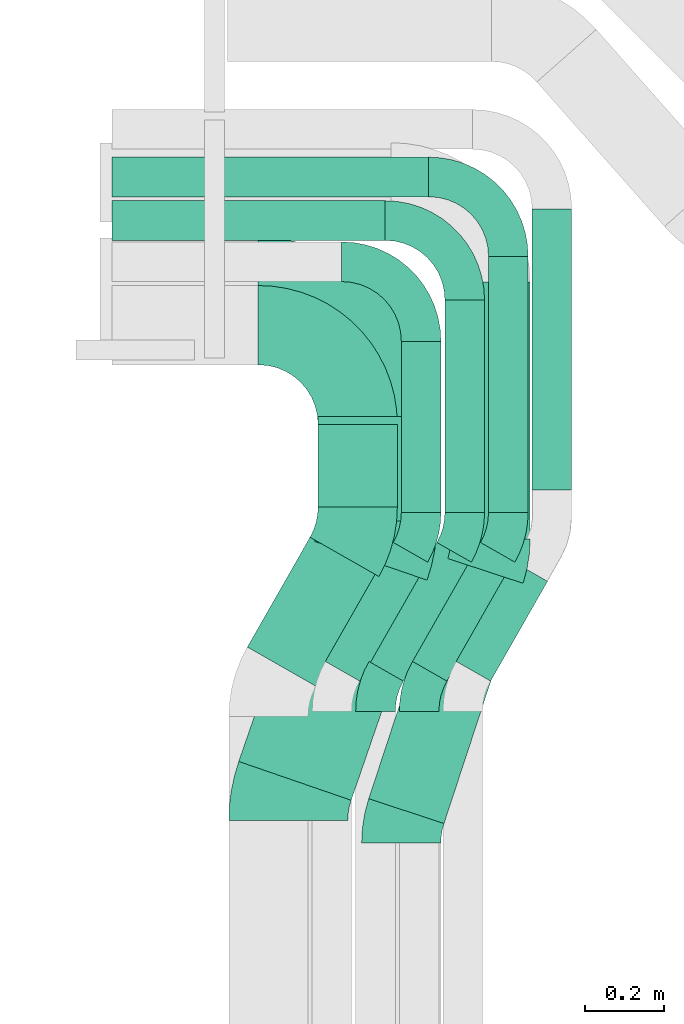
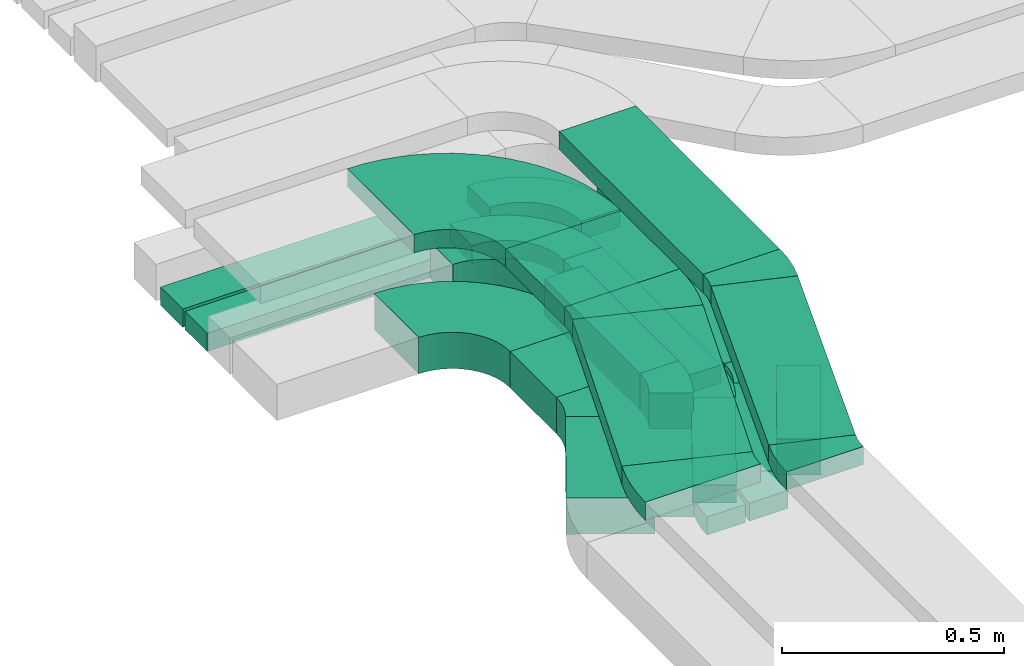
# One storey, part 6 of 31: 16 flow segments, 15 flow fittings.
"""IFC2X3 building model written with IfcOpenShell, lengths in millimetres."""

from ifc_helpers import new_model, entity, si_unit, converted_unit, derived_unit, direction, frame, frame_2d, origin, origin_2d_with_axis, place, context, subcontext, project, spatial, polyline, circle_curve, parameter, trimmed, segment, composite_curve, rectangle, outline, extrude, source, transform, mapped, material, type_object, type_shapes, element, save


model = new_model("IFC2X3")

# Units and contexts
model_context = context("Model", 3, precision=0.01, world=origin(), true_north=direction((6.12303176911189e-17, 1.0)))
body_context = subcontext(model_context, "Body", "Model", "MODEL_VIEW")
ifc_project = project(units=[si_unit("LENGTHUNIT", "METRE", prefix="MILLI"), si_unit("AREAUNIT", "SQUARE_METRE"), si_unit("VOLUMEUNIT", "CUBIC_METRE"), converted_unit("PLANEANGLEUNIT", "DEGREE", entity("IfcRatioMeasure", 0.0174532925199433), si_unit("PLANEANGLEUNIT", "RADIAN"), dimensions=[0, 0, 0, 0, 0, 0, 0]), si_unit("MASSUNIT", "GRAM", prefix="KILO"), derived_unit("MASSDENSITYUNIT", [(si_unit("MASSUNIT", "GRAM", prefix="KILO"), 1), (si_unit("LENGTHUNIT", "METRE"), -3)]), derived_unit("MOMENTOFINERTIAUNIT", [(si_unit("LENGTHUNIT", "METRE"), 4)]), si_unit("TIMEUNIT", "SECOND"), si_unit("FREQUENCYUNIT", "HERTZ"), si_unit("THERMODYNAMICTEMPERATUREUNIT", "DEGREE_CELSIUS"), derived_unit("THERMALTRANSMITTANCEUNIT", [(si_unit("MASSUNIT", "GRAM", prefix="KILO"), 1), (si_unit("THERMODYNAMICTEMPERATUREUNIT", "KELVIN"), -1), (si_unit("TIMEUNIT", "SECOND"), -3)]), derived_unit("VOLUMETRICFLOWRATEUNIT", [(si_unit("LENGTHUNIT", "METRE"), 3), (si_unit("TIMEUNIT", "SECOND"), -1)]), derived_unit("MASSFLOWRATEUNIT", [(si_unit("MASSUNIT", "GRAM", prefix="KILO"), 1), (si_unit("TIMEUNIT", "SECOND"), -1)]), derived_unit("ROTATIONALFREQUENCYUNIT", [(si_unit("TIMEUNIT", "SECOND"), -1)]), si_unit("ELECTRICCURRENTUNIT", "AMPERE"), si_unit("ELECTRICVOLTAGEUNIT", "VOLT"), si_unit("POWERUNIT", "WATT"), si_unit("FORCEUNIT", "NEWTON", prefix="KILO"), si_unit("ILLUMINANCEUNIT", "LUX"), si_unit("LUMINOUSFLUXUNIT", "LUMEN"), si_unit("LUMINOUSINTENSITYUNIT", "CANDELA"), derived_unit("USERDEFINED", [(si_unit("MASSUNIT", "GRAM", prefix="KILO"), -1), (si_unit("LENGTHUNIT", "METRE"), -2), (si_unit("TIMEUNIT", "SECOND"), 3), (si_unit("LUMINOUSFLUXUNIT", "LUMEN"), 1)]), derived_unit("LINEARVELOCITYUNIT", [(si_unit("LENGTHUNIT", "METRE"), 1), (si_unit("TIMEUNIT", "SECOND"), -1)]), si_unit("PRESSUREUNIT", "PASCAL"), derived_unit("USERDEFINED", [(si_unit("LENGTHUNIT", "METRE"), -2), (si_unit("MASSUNIT", "GRAM", prefix="KILO"), 1), (si_unit("TIMEUNIT", "SECOND"), -2)]), derived_unit("LINEARFORCEUNIT", [(si_unit("MASSUNIT", "GRAM", prefix="KILO"), 1), (si_unit("LENGTHUNIT", "METRE"), 1), (si_unit("TIMEUNIT", "SECOND"), -2), (si_unit("LENGTHUNIT", "METRE"), -1)]), derived_unit("PLANARFORCEUNIT", [(si_unit("MASSUNIT", "GRAM", prefix="KILO"), 1), (si_unit("LENGTHUNIT", "METRE"), 1), (si_unit("TIMEUNIT", "SECOND"), -2), (si_unit("LENGTHUNIT", "METRE"), -2)])], contexts=[model_context])

# Site, building, storey
site_placement = place(None, frame((0.0, -0.00077364408347762, 0.0)))
site = spatial("IfcSite", under=ifc_project, at=site_placement, CompositionType="ELEMENT")
building_placement = place(site_placement, origin())
building = spatial("IfcBuilding", under=site, at=building_placement, CompositionType="ELEMENT")
storey_placement = place(building_placement, frame((0.0, 0.0, 15900.0)))
storey = spatial("IfcBuildingStorey", under=building, at=storey_placement, CompositionType="ELEMENT", Elevation=15900.0)

# Flow segments
cable_carrier_segment_type = type_object("IfcCableCarrierSegmentType", PredefinedType="CABLETRAYSEGMENT")
flow_segment_1_placement = place(storey_placement, frame((17298.5446118447, 13653.748634585, 2607.25805153974)))
element("IfcFlowSegment", 1, at=flow_segment_1_placement, inside=storey, type_object=cable_carrier_segment_type, context=body_context, shape_type="SweptSolid", body=[
    extrude(rectangle(XDim=709.169713057409, YDim=99.9999999999989, at=origin_2d_with_axis()), frame((50.0, 354.584856528705, 0.0), z_axis=(0.0, 0.0, 1.0), x_axis=(0.0, 1.0, 0.0)), (0.0, 0.0, 1.0), 99.9999999999989),
])
flow_segment_2_placement = place(storey_placement, frame((16968.5446118447, 13597.9985929321, 2607.25805153974)))
element("IfcFlowSegment", 2, at=flow_segment_2_placement, inside=storey, type_object=cable_carrier_segment_type, context=body_context, shape_type="SweptSolid", body=[
    extrude(rectangle(XDim=431.001407067845, YDim=99.9999999999989, at=frame_2d((0.0, 1.08357767203415e-12), x_axis=(1.0, 0.0))), frame((50.0, 215.500703533923, 0.0), z_axis=(0.0, 0.0, 1.0), x_axis=(0.0, 1.0, 0.0)), (0.0, 0.0, 1.0), 99.9999999999989),
])
flow_segment_3_placement = place(storey_placement, frame((17078.5446118447, 13597.9985929321, 2607.25805153974)))
element("IfcFlowSegment", 3, at=flow_segment_3_placement, inside=storey, type_object=cable_carrier_segment_type, context=body_context, shape_type="SweptSolid", body=[
    extrude(rectangle(XDim=534.919754710368, YDim=99.9999999999989, at=frame_2d((0.0, -1.08357767203415e-12), x_axis=(1.0, 0.0))), frame((50.0, 267.459877355185, 0.0), z_axis=(0.0, 0.0, 1.0), x_axis=(0.0, 1.0, 0.0)), (0.0, 0.0, 1.0), 50.0000000000016),
])
flow_segment_4_placement = place(storey_placement, frame((16758.5446118447, 13611.2686542545, 2607.25805153974)))
element("IfcFlowSegment", 4, at=flow_segment_4_placement, inside=storey, type_object=cable_carrier_segment_type, context=body_context, shape_type="SweptSolid", body=[
    extrude(rectangle(XDim=207.731345745393, YDim=200.000000000002, at=frame_2d((-1.08002495835535e-12, -1.08713038571295e-12), x_axis=(1.0, 0.0))), frame((100.0, 103.865672872701, 0.0), z_axis=(0.0, 0.0, 1.0), x_axis=(0.0, 1.0, 0.0)), (0.0, 0.0, 1.0), 99.9999999999989),
])
flow_segment_5_placement = place(storey_placement, frame((17093.5446118446, 13530.0937932335, 2927.25805153973)))
element("IfcFlowSegment", 5, at=flow_segment_5_placement, inside=storey, type_object=cable_carrier_segment_type, context=body_context, shape_type="SweptSolid", body=[
    extrude(rectangle(XDim=649.073739865579, YDim=200.000000000002, at=frame_2d((1.08002495835535e-12, 0.0), x_axis=(1.0, 0.0))), frame((100.0, 324.536869932802, 0.0), z_axis=(0.0, 0.0, 1.0), x_axis=(0.0, 1.0, 0.0)), (0.0, 0.0, 1.0), 50.0000000000016),
])
flow_segment_6_placement = place(storey_placement, frame((16758.5446118446, 13575.3280194465, 2927.25805153973)))
element("IfcFlowSegment", 6, at=flow_segment_6_placement, inside=storey, type_object=cable_carrier_segment_type, context=body_context, shape_type="SweptSolid", body=[
    extrude(rectangle(XDim=264.198022174949, YDim=300.000000000001, at=frame_2d((1.08002495835535e-12, 0.0), x_axis=(1.0, 0.0))), frame((150.0, 132.099011087491, 0.0), z_axis=(0.0, 0.0, 1.0), x_axis=(0.0, 1.0, 0.0)), (0.0, 0.0, 1.0), 50.0000000000016),
])
flow_segment_7_placement = place(storey_placement, frame((17188.5446118447, 13597.9985929321, 2607.25805153974)))
element("IfcFlowSegment", 7, at=flow_segment_7_placement, inside=storey, type_object=cable_carrier_segment_type, context=body_context, shape_type="SweptSolid", body=[
    extrude(rectangle(XDim=644.919754710367, YDim=99.9999999999989, at=origin_2d_with_axis()), frame((50.0, 322.459877355184, 0.0), z_axis=(0.0, 0.0, 1.0), x_axis=(0.0, 1.0, 0.0)), (0.0, 0.0, 1.0), 50.0000000000016),
])
flow_segment_8_placement = place(storey_placement, frame((16580.0578379621, 13158.71056033, 2607.25805153974)))
element("IfcFlowSegment", 8, at=flow_segment_8_placement, inside=storey, type_object=cable_carrier_segment_type, context=body_context, shape_type="SweptSolid", body=[
    extrude(rectangle(XDim=319.133502209689, YDim=199.999999999999, at=frame_2d((5.25801624462474e-13, -9.37916411203332e-13), x_axis=(1.0, 0.0))), frame((165.964467960225, 188.154287590096, 0.0), z_axis=(0.0, 0.0, 1.0), x_axis=(-0.495874162367818, -0.868394389143559, 0.0)), (0.0, 0.0, 1.0), 99.9999999999989),
])
flow_segment_9_placement = place(storey_placement, frame((17106.8972768765, 13171.9806216524, 2607.25805153974)))
element("IfcFlowSegment", 9, at=flow_segment_9_placement, inside=storey, type_object=cable_carrier_segment_type, context=body_context, shape_type="SweptSolid", body=[
    extrude(rectangle(XDim=289.923583201512, YDim=100.000000000003, at=frame_2d((3.83693077310454e-13, 1.47792889038101e-12), x_axis=(1.0, 0.0))), frame((115.302526442549, 150.677714584686, 0.0), z_axis=(0.0, 0.0, 1.0), x_axis=(-0.495874162367868, -0.868394389143531, 0.0)), (0.0, 0.0, 1.0), 99.9999999999989),
])
flow_segment_10_placement = place(storey_placement, frame((16776.8972768765, 13171.9806216524, 2607.25805153974)))
element("IfcFlowSegment", 10, at=flow_segment_10_placement, inside=storey, type_object=cable_carrier_segment_type, context=body_context, shape_type="SweptSolid", body=[
    extrude(rectangle(XDim=345.673624854465, YDim=100.000000000001, at=frame_2d((5.40012479177676e-13, -9.45021838560933e-13), x_axis=(1.0, 0.0))), frame((129.125029045863, 174.884226267655, 0.0), z_axis=(0.0, 0.0, 1.0), x_axis=(-0.495874162367857, -0.868394389143537, 0.0)), (0.0, 0.0, 1.0), 99.9999999999989),
])
flow_segment_11_placement = place(storey_placement, frame((16886.8972768765, 13171.9806216524, 2607.25805153974)))
element("IfcFlowSegment", 11, at=flow_segment_11_placement, inside=storey, type_object=cable_carrier_segment_type, context=body_context, shape_type="SweptSolid", body=[
    extrude(rectangle(XDim=345.67362485447, YDim=100.000000000001, at=origin_2d_with_axis()), frame((129.125029045863, 174.884226267657, 0.0), z_axis=(0.0, 0.0, 1.0), x_axis=(-0.495874162367856, -0.868394389143537, 0.0)), (0.0, 0.0, 1.0), 50.0000000000016),
])
flow_segment_12_placement = place(storey_placement, frame((16996.8972768765, 13171.9806216524, 2607.25805153974)))
element("IfcFlowSegment", 12, at=flow_segment_12_placement, inside=storey, type_object=cable_carrier_segment_type, context=body_context, shape_type="SweptSolid", body=[
    extrude(rectangle(XDim=345.67362485447, YDim=100.000000000001, at=frame_2d((1.08002495835535e-12, -1.87938553608547e-12), x_axis=(1.0, 0.0))), frame((129.125029045865, 174.884226267657, 0.0), z_axis=(0.0, 0.0, 1.0), x_axis=(-0.495874162367856, -0.868394389143537, 0.0)), (0.0, 0.0, 1.0), 50.0000000000016),
])
flow_segment_13_placement = place(storey_placement, frame((16238.5446118447, 14283.9183476424, 2607.25805153973)))
element("IfcFlowSegment", 13, at=flow_segment_13_placement, inside=storey, type_object=cable_carrier_segment_type, context=body_context, shape_type="SweptSolid", body=[
    extrude(rectangle(XDim=689.000000000006, YDim=99.9999999999989, at=frame_2d((-1.08002495835535e-12, -1.08357767203415e-12), x_axis=(1.0, 0.0))), frame((344.500000000004, 50.0, 0.0), z_axis=(0.0, 0.0, 1.0), x_axis=(-1.0, 0.0, 0.0)), (0.0, 0.0, 1.0), 50.0000000000016),
])
flow_segment_14_placement = place(storey_placement, frame((16238.5446118447, 14393.9183476424, 2607.25805153973)))
element("IfcFlowSegment", 14, at=flow_segment_14_placement, inside=storey, type_object=cable_carrier_segment_type, context=body_context, shape_type="SweptSolid", body=[
    extrude(rectangle(XDim=799.000000000003, YDim=99.9999999999989, at=frame_2d((1.08002495835535e-12, 1.08357767203415e-12), x_axis=(1.0, 0.0))), frame((399.5, 50.0, 0.0), z_axis=(0.0, 0.0, 1.0), x_axis=(-1.0, 0.0, 0.0)), (0.0, 0.0, 1.0), 50.0000000000016),
])
flow_segment_15_placement = place(storey_placement, frame((16558.4376559848, 12871.3887283944, 2927.25805153973)))
element("IfcFlowSegment", 15, at=flow_segment_15_placement, inside=storey, type_object=cable_carrier_segment_type, context=body_context, shape_type="SweptSolid", body=[
    extrude(rectangle(XDim=587.335852841362, YDim=299.999999999998, at=origin_2d_with_axis()), frame((237.584649937534, 326.533524512426, 0.0), z_axis=(0.0, 0.0, 1.0), x_axis=(-0.326179561314503, -0.945307830169981, 0.0)), (0.0, 0.0, 1.0), 50.0000000000016),
])
flow_segment_16_placement = place(storey_placement, frame((16886.3434289038, 12812.7533058903, 2927.25805153973)))
element("IfcFlowSegment", 16, at=flow_segment_16_placement, inside=storey, type_object=cable_carrier_segment_type, context=body_context, shape_type="SweptSolid", body=[
    extrude(rectangle(XDim=637.96363640816, YDim=200.000000000001, at=frame_2d((-1.36424205265939e-12, 6.96331881044898e-13), x_axis=(1.0, 0.0))), frame((194.678877018582, 334.256402864071, 0.0), z_axis=(0.0, 0.0, 1.0), x_axis=(0.312518466204231, 0.949911684464064, 0.0)), (0.0, 0.0, 1.0), 50.0000000000016),
])

# Flow fittings
ifc_material = material()
cable_carrier_fitting_type_1 = type_object("IfcCableCarrierFittingType", Name="470_DKC_S5_Variable Angle Elbow 0-45:-", PredefinedType="NOTDEFINED", material=ifc_material)
shared_shape_1 = source(origin(), body_context, "Body", "SweptSolid", [
    extrude(outline(composite_curve([segment(polyline([(-100.749999999999, -150.250000000001), (-99.7499999999981, -150.250000000001)]), True, "CONTINUOUS"), segment(trimmed(circle_curve(frame_2d((-99.7500000000006, 99.7499999999987), x_axis=(0.0, -1.0)), 250.0), [parameter(0.0)], [parameter(90.0000000000001)], True, "PARAMETER"), True, "CONTINUOUS"), segment(polyline([(150.249999999999, 99.7500000000013), (150.249999999999, 100.750000000001)]), True, "CONTINUOUS"), segment(polyline([(150.249999999999, 100.750000000001), (50.2499999999992, 100.750000000001)]), True, "CONTINUOUS"), segment(polyline([(50.2499999999992, 100.750000000001), (50.2499999999992, 99.7500000000002)]), True, "CONTINUOUS"), segment(trimmed(circle_curve(frame_2d((-99.7500000000006, 99.7499999999987), x_axis=(0.0, -1.0)), 150.0), [parameter(0.0)], [parameter(90.0000000000001)], True, "PARAMETER"), False, "CONTINUOUS"), segment(polyline([(-99.7499999999989, -50.2500000000011), (-100.75, -50.2500000000011)]), True, "CONTINUOUS"), segment(polyline([(-100.75, -50.2500000000011), (-100.749999999999, -150.250000000001)]), True, "CONTINUOUS")], self_intersect=False)), frame((-100.249999999991, 100.249999999992, -50.0)), (0.0, 0.0, 1.0), 100.0),
])
type_shapes(cable_carrier_fitting_type_1, [shared_shape_1])
flow_fitting_1_placement = place(storey_placement, frame((17018.5446118447, 14230.0, 2657.25805153974), z_axis=(0.0, 0.0, 1.0), x_axis=(0.0, 1.0, 0.0)))
element("IfcFlowFitting", 17, at=flow_fitting_1_placement, inside=storey, type_object=cable_carrier_fitting_type_1, material=ifc_material, Name="470_DKC_S5_Variable Angle Elbow 0-45:-", ObjectType="470_DKC_S5_Variable Angle Elbow 0-45:-", context=body_context, shape_type="MappedRepresentation", body=[
    mapped(shared_shape_1, transform((0.0, 0.0, 0.0), scale=1.0)),
])
cable_carrier_fitting_type_2 = type_object("IfcCableCarrierFittingType", Name="470_DKC_S5_Variable Angle Elbow 0-45:-", PredefinedType="NOTDEFINED", material=ifc_material)
shared_shape_2 = source(origin(), body_context, "Body", "SweptSolid", [
    extrude(outline(composite_curve([segment(polyline([(-100.750000000001, -150.25), (-99.7499999999994, -150.25)]), True, "CONTINUOUS"), segment(trimmed(circle_curve(frame_2d((-99.7499999999997, 99.7499999999995), x_axis=(0.0, -1.0)), 250.0), [parameter(0.0)], [parameter(90.0000000000001)], True, "PARAMETER"), True, "CONTINUOUS"), segment(polyline([(150.25, 99.75), (150.25, 100.749999999999)]), True, "CONTINUOUS"), segment(polyline([(150.25, 100.749999999999), (50.25, 100.75)]), True, "CONTINUOUS"), segment(polyline([(50.25, 100.75), (50.25, 99.7499999999998)]), True, "CONTINUOUS"), segment(trimmed(circle_curve(frame_2d((-99.7499999999997, 99.7499999999995), x_axis=(0.0, -1.0)), 150.0), [parameter(0.0)], [parameter(90.0000000000001)], True, "PARAMETER"), False, "CONTINUOUS"), segment(polyline([(-99.7499999999994, -50.2500000000003), (-100.750000000001, -50.2500000000003)]), True, "CONTINUOUS"), segment(polyline([(-100.750000000001, -50.2500000000003), (-100.750000000001, -150.25)]), True, "CONTINUOUS")], self_intersect=False)), frame((-100.249999999991, 100.249999999992, -25.0)), (0.0, 0.0, 1.0), 49.9999999999997),
])
type_shapes(cable_carrier_fitting_type_2, [shared_shape_2])
for number, where, z_axis, x_axis, name in (
    (18, (17128.5446118447, 14333.9183476424, 2632.25805153974), (0.0, 0.0, 1.0), (0.0, 1.0, 0.0), "470_DKC_S5_Variable Angle Elbow 0-45:-"),
    (19, (17238.5446118447, 14443.9183476424, 2632.25805153974), (0.0, 0.0, 1.0), (0.0, 1.0, 0.0), "470_DKC_S5_Variable Angle Elbow 0-45:-"),
):
    element("IfcFlowFitting", number, at=place(storey_placement, frame(where, z_axis=z_axis, x_axis=x_axis)), inside=storey, type_object=cable_carrier_fitting_type_2, material=ifc_material, Name=name, ObjectType="470_DKC_S5_Variable Angle Elbow 0-45:-", context=body_context, shape_type="MappedRepresentation", body=[
        mapped(shared_shape_2, transform((0.0, 0.0, 0.0), scale=1.0)),
    ])
cable_carrier_fitting_type_3 = type_object("IfcCableCarrierFittingType", Name="470_DKC_S5_Variable Angle Elbow 0-45:-", PredefinedType="NOTDEFINED", material=ifc_material)
shared_shape_3 = source(origin(), body_context, "Body", "SweptSolid", [
    extrude(outline(composite_curve([segment(polyline([(-125.750000000001, -225.25), (-124.749999999999, -225.25)]), True, "CONTINUOUS"), segment(trimmed(circle_curve(frame_2d((-124.75, 124.75), x_axis=(0.0, -1.0)), 350.0), [parameter(0.0)], [parameter(90.0000000000001)], True, "PARAMETER"), True, "CONTINUOUS"), segment(polyline([(225.25, 124.75), (225.25, 125.749999999999)]), True, "CONTINUOUS"), segment(polyline([(225.25, 125.749999999999), (25.25, 125.750000000001)]), True, "CONTINUOUS"), segment(polyline([(25.25, 125.750000000001), (25.25, 124.75)]), True, "CONTINUOUS"), segment(trimmed(circle_curve(frame_2d((-124.75, 124.75), x_axis=(0.0, -1.0)), 150.0), [parameter(0.0)], [parameter(90.0000000000001)], True, "PARAMETER"), False, "CONTINUOUS"), segment(polyline([(-124.749999999999, -25.2500000000003), (-125.750000000001, -25.2500000000003)]), True, "CONTINUOUS"), segment(polyline([(-125.750000000001, -25.2500000000003), (-125.750000000001, -225.25)]), True, "CONTINUOUS")], self_intersect=False)), frame((-125.249999999991, 125.249999999992, -50.0)), (0.0, 0.0, 1.0), 100.0),
])
type_shapes(cable_carrier_fitting_type_3, [shared_shape_3])
flow_fitting_2_placement = place(storey_placement, frame((16858.5446118447, 14070.0, 2657.25805153974), z_axis=(0.0, 0.0, 1.0), x_axis=(0.0, 1.0, 0.0)))
element("IfcFlowFitting", 20, at=flow_fitting_2_placement, inside=storey, type_object=cable_carrier_fitting_type_3, material=ifc_material, Name="470_DKC_S5_Variable Angle Elbow 0-45:-", ObjectType="470_DKC_S5_Variable Angle Elbow 0-45:-", context=body_context, shape_type="MappedRepresentation", body=[
    mapped(shared_shape_3, transform((0.0, 0.0, 0.0), scale=1.0)),
])
cable_carrier_fitting_type_4 = type_object("IfcCableCarrierFittingType", Name="470_DKC_S5_Variable Angle Elbow 0-45:-", PredefinedType="NOTDEFINED", material=ifc_material)
shared_shape_4 = source(origin(), body_context, "Body", "SweptSolid", [
    extrude(outline(composite_curve([segment(polyline([(-150.749999999996, -300.250000000003), (-149.749999999994, -300.250000000003)]), True, "CONTINUOUS"), segment(trimmed(circle_curve(frame_2d((-149.750000000002, 149.749999999997), x_axis=(0.0, -1.0)), 450.0), [parameter(0.0)], [parameter(90.0000000000001)], True, "PARAMETER"), True, "CONTINUOUS"), segment(polyline([(300.249999999997, 149.750000000005), (300.249999999997, 150.750000000004)]), True, "CONTINUOUS"), segment(polyline([(300.249999999997, 150.750000000003), (0.249999999997449, 150.750000000002)]), True, "CONTINUOUS"), segment(polyline([(0.249999999997449, 150.750000000002), (0.249999999997438, 149.75)]), True, "CONTINUOUS"), segment(trimmed(circle_curve(frame_2d((-149.750000000002, 149.749999999997), x_axis=(0.0, -1.0)), 150.0), [parameter(0.0)], [parameter(90.0000000000001)], True, "PARAMETER"), False, "CONTINUOUS"), segment(polyline([(-149.749999999999, -0.250000000002818), (-150.750000000001, -0.250000000002835)]), True, "CONTINUOUS"), segment(polyline([(-150.750000000001, -0.250000000002835), (-150.749999999996, -300.250000000003)]), True, "CONTINUOUS")], self_intersect=False)), frame((-150.249999999991, 150.249999999992, -25.0)), (0.0, 0.0, 1.0), 49.9999999999974),
])
type_shapes(cable_carrier_fitting_type_4, [shared_shape_4])
flow_fitting_3_placement = place(storey_placement, frame((16908.5446118446, 14140.5260416215, 2952.25805153973), z_axis=(0.0, 0.0, 1.0), x_axis=(0.0, 1.0, 0.0)))
element("IfcFlowFitting", 21, at=flow_fitting_3_placement, inside=storey, type_object=cable_carrier_fitting_type_4, material=ifc_material, Name="470_DKC_S5_Variable Angle Elbow 0-45:-", ObjectType="470_DKC_S5_Variable Angle Elbow 0-45:-", context=body_context, shape_type="MappedRepresentation", body=[
    mapped(shared_shape_4, transform((0.0, 0.0, 0.0), scale=1.0)),
])
cable_carrier_fitting_type_5 = type_object("IfcCableCarrierFittingType", Name="470_DKC_S5_Variable Angle Elbow 0-45:-", PredefinedType="NOTDEFINED", material=ifc_material)
shared_shape_5 = source(origin(), body_context, "Body", "SweptSolid", [
    extrude(outline(composite_curve([segment(polyline([(-62.9513688932596, -116.574669897645), (-61.9513688932584, -116.574669897645)]), True, "CONTINUOUS"), segment(trimmed(circle_curve(frame_2d((-61.9513688932588, 233.425330102355), x_axis=(0.0, -1.0)), 350.0), [parameter(0.0)], [parameter(29.7274101248659)], True, "PARAMETER"), True, "CONTINUOUS"), segment(polyline([(111.604587935465, -70.5127060978972), (112.472982324609, -70.0168319355294)]), True, "CONTINUOUS"), segment(polyline([(112.472982324609, -70.0168319355294), (13.2981498510523, 103.662045893186)]), True, "CONTINUOUS"), segment(polyline([(13.2981498510523, 103.662045893186), (12.4297554619086, 103.166171730818)]), True, "CONTINUOUS"), segment(trimmed(circle_curve(frame_2d((-61.9513688932588, 233.425330102355), x_axis=(0.0, -1.0)), 150.0), [parameter(0.0)], [parameter(29.7274101248659)], True, "PARAMETER"), False, "CONTINUOUS"), segment(polyline([(-61.9513688932584, 83.4253301023552), (-62.9513688932596, 83.4253301023552)]), True, "CONTINUOUS"), segment(polyline([(-62.9513688932596, 83.4253301023552), (-62.9513688932596, -116.574669897645)]), True, "CONTINUOUS")], self_intersect=False)), frame((-4.39893771880046, 16.5746698976365, -50.0)), (0.0, 0.0, 1.0), 100.0),
])
type_shapes(cable_carrier_fitting_type_5, [shared_shape_5])
flow_fitting_4_placement = place(storey_placement, frame((16858.5446118446, 13543.9183476424, 2657.25805153974), z_axis=(0.0, 0.0, 1.0), x_axis=(0.495874162367799, 0.86839438914357, 0.0)))
element("IfcFlowFitting", 22, at=flow_fitting_4_placement, inside=storey, type_object=cable_carrier_fitting_type_5, material=ifc_material, Name="470_DKC_S5_Variable Angle Elbow 0-45:-", ObjectType="470_DKC_S5_Variable Angle Elbow 0-45:-", context=body_context, shape_type="MappedRepresentation", body=[
    mapped(shared_shape_5, transform((0.0, 0.0, 0.0), scale=1.0)),
])
cable_carrier_fitting_type_6 = type_object("IfcCableCarrierFittingType", Name="470_DKC_S5_Variable Angle Elbow 0-45:-", PredefinedType="NOTDEFINED", material=ifc_material)
shared_shape_6 = source(origin(), body_context, "Body", "SweptSolid", [
    extrude(outline(composite_curve([segment(polyline([(-50.5545148340685, -63.2845296262368), (-49.5545148340673, -63.2845296262368)]), True, "CONTINUOUS"), segment(trimmed(circle_curve(frame_2d((-49.5545148340698, 186.715470373763), x_axis=(0.0, -1.0)), 250.0), [parameter(0.0)], [parameter(29.7274101248686)], True, "PARAMETER"), True, "CONTINUOUS"), segment(polyline([(74.4140257578879, -30.3831269121247), (75.2824201470313, -29.8872527497569)]), True, "CONTINUOUS"), segment(polyline([(75.2824201470314, -29.8872527497569), (25.6950039102484, 56.9521861645982)]), True, "CONTINUOUS"), segment(polyline([(25.6950039102484, 56.9521861645982), (24.8266095211048, 56.4563120022303)]), True, "CONTINUOUS"), segment(trimmed(circle_curve(frame_2d((-49.5545148340698, 186.715470373763), x_axis=(0.0, -1.0)), 150.0), [parameter(0.0)], [parameter(29.7274101248686)], True, "PARAMETER"), False, "CONTINUOUS"), segment(polyline([(-49.5545148340682, 36.7154703737631), (-50.5545148340694, 36.7154703737631)]), True, "CONTINUOUS"), segment(polyline([(-50.5545148340694, 36.7154703737631), (-50.5545148340685, -63.2845296262368)]), True, "CONTINUOUS")], self_intersect=False)), frame((-3.52573045558226, 13.2845296262283, -50.0)), (0.0, 0.0, 1.0), 100.0),
])
type_shapes(cable_carrier_fitting_type_6, [shared_shape_6])
flow_fitting_5_placement = place(storey_placement, frame((17018.5446118446, 13543.9183476424, 2657.25805153974), z_axis=(0.0, 0.0, 1.0), x_axis=(0.495874162367838, 0.868394389143548, 0.0)))
element("IfcFlowFitting", 23, at=flow_fitting_5_placement, inside=storey, type_object=cable_carrier_fitting_type_6, material=ifc_material, Name="470_DKC_S5_Variable Angle Elbow 0-45:-", ObjectType="470_DKC_S5_Variable Angle Elbow 0-45:-", context=body_context, shape_type="MappedRepresentation", body=[
    mapped(shared_shape_6, transform((0.0, 0.0, 0.0), scale=1.0)),
])
cable_carrier_fitting_type_7 = type_object("IfcCableCarrierFittingType", Name="470_DKC_S5_Variable Angle Elbow 0-45:-", PredefinedType="NOTDEFINED", material=ifc_material)
shared_shape_7 = source(origin(), body_context, "Body", "SweptSolid", [
    extrude(outline(composite_curve([segment(polyline([(-50.5545148340689, -63.2845296262363), (-49.5545148340676, -63.2845296262363)]), True, "CONTINUOUS"), segment(trimmed(circle_curve(frame_2d((-49.5545148340681, 186.715470373763), x_axis=(0.0, -1.0)), 250.0), [parameter(0.0)], [parameter(29.7274101248684)], True, "PARAMETER"), True, "CONTINUOUS"), segment(polyline([(74.4140257578874, -30.3831269121254), (75.2824201470309, -29.8872527497576)]), True, "CONTINUOUS"), segment(polyline([(75.2824201470309, -29.8872527497576), (25.6950039102487, 56.9521861645979)]), True, "CONTINUOUS"), segment(polyline([(25.6950039102487, 56.9521861645979), (24.8266095211052, 56.4563120022301)]), True, "CONTINUOUS"), segment(trimmed(circle_curve(frame_2d((-49.5545148340681, 186.715470373763), x_axis=(0.0, -1.0)), 150.0), [parameter(0.0)], [parameter(29.7274101248684)], True, "PARAMETER"), False, "CONTINUOUS"), segment(polyline([(-49.5545148340676, 36.7154703737636), (-50.5545148340689, 36.7154703737636)]), True, "CONTINUOUS"), segment(polyline([(-50.5545148340689, 36.7154703737636), (-50.5545148340689, -63.2845296262363)]), True, "CONTINUOUS")], self_intersect=False)), frame((-3.52573045558215, 13.2845296262282, -25.0)), (0.0, 0.0, 1.0), 50.0),
])
type_shapes(cable_carrier_fitting_type_7, [shared_shape_7])
for number, where, z_axis, x_axis, name in (
    (24, (17128.5446118446, 13543.9183476424, 2632.25805153974), (0.0, 0.0, 1.0), (0.495874162367837, 0.868394389143548, 0.0), "470_DKC_S5_Variable Angle Elbow 0-45:-"),
    (25, (16903.5, 13149.8113481978, 2632.25805153974), (0.0, 0.0, 1.0), (-0.495874162367856, -0.868394389143537, 0.0), "470_DKC_S5_Variable Angle Elbow 0-45:-"),
    (26, (17238.5446118446, 13543.9183476424, 2632.25805153974), (0.0, 0.0, 1.0), (0.495874162367837, 0.868394389143548, 0.0), "470_DKC_S5_Variable Angle Elbow 0-45:-"),
    (27, (17013.5, 13149.8113481978, 2632.25805153974), (0.0, 0.0, 1.0), (-0.495874162367856, -0.868394389143537, 0.0), "470_DKC_S5_Variable Angle Elbow 0-45:-"),
):
    element("IfcFlowFitting", number, at=place(storey_placement, frame(where, z_axis=z_axis, x_axis=x_axis)), inside=storey, type_object=cable_carrier_fitting_type_7, material=ifc_material, Name=name, ObjectType="470_DKC_S5_Variable Angle Elbow 0-45:-", context=body_context, shape_type="MappedRepresentation", body=[
        mapped(shared_shape_7, transform((0.0, 0.0, 0.0), scale=1.0)),
    ])
cable_carrier_fitting_type_8 = type_object("IfcCableCarrierFittingType", Name="470_DKC_S5_Variable Angle Elbow 0-45:-", PredefinedType="NOTDEFINED", material=ifc_material)
shared_shape_8 = source(origin(), body_context, "Body", "SweptSolid", [
    extrude(outline(composite_curve([segment(polyline([(-49.9132611547124, -158.285370364831), (-48.913261154711, -158.285370364831)]), True, "CONTINUOUS"), segment(trimmed(circle_curve(frame_2d((-48.9132611547192, 291.714629635169), x_axis=(0.0, -1.0)), 450.0), [parameter(0.0)], [parameter(19.0370536725762)], True, "PARAMETER"), True, "CONTINUOUS"), segment(polyline([(97.8675414368031, -133.673893941324), (98.8128492669727, -133.34771438001)]), True, "CONTINUOUS"), segment(polyline([(98.8128492669727, -133.34771438001), (0.958980872625161, 150.244634670986)]), True, "CONTINUOUS"), segment(polyline([(0.958980872625186, 150.244634670986), (0.013673042454844, 149.918455109671)]), True, "CONTINUOUS"), segment(trimmed(circle_curve(frame_2d((-48.9132611547192, 291.714629635169), x_axis=(0.0, -1.0)), 150.0), [parameter(0.0)], [parameter(19.0370536725762)], True, "PARAMETER"), False, "CONTINUOUS"), segment(polyline([(-48.9132611547161, 141.714629635169), (-49.9132611547175, 141.714629635169)]), True, "CONTINUOUS"), segment(polyline([(-49.9132611547175, 141.714629635169), (-49.9132611547124, -158.285370364831)]), True, "CONTINUOUS")], self_intersect=False)), frame((-1.3892497778477, 8.28537036482204, -25.0)), (0.0, 0.0, 1.0), 49.9999999999993),
])
type_shapes(cable_carrier_fitting_type_8, [shared_shape_8])
for number, where, z_axis, x_axis, name in (
    (28, (16908.5446118446, 13524.025508514, 2952.25805153973), (0.0, 0.0, 1.0), (0.32617956131449, 0.945307830169986, 0.0), "470_DKC_S5_Variable Angle Elbow 0-45:-"),
    (29, (16683.5, 12871.8189972996, 2952.25805153973), (0.0, 0.0, 1.0), (-0.326179561314503, -0.945307830169981, 0.0), "470_DKC_S5_Variable Angle Elbow 0-45:-"),
):
    element("IfcFlowFitting", number, at=place(storey_placement, frame(where, z_axis=z_axis, x_axis=x_axis)), inside=storey, type_object=cable_carrier_fitting_type_8, material=ifc_material, Name=name, ObjectType="470_DKC_S5_Variable Angle Elbow 0-45:-", context=body_context, shape_type="MappedRepresentation", body=[
        mapped(shared_shape_8, transform((0.0, 0.0, 0.0), scale=1.0)),
    ])
cable_carrier_fitting_type_9 = type_object("IfcCableCarrierFittingType", Name="470_DKC_S5_Variable Angle Elbow 0-45:-", PredefinedType="NOTDEFINED", material=ifc_material)
shared_shape_9 = source(origin(), body_context, "Body", "SweptSolid", [
    extrude(outline(composite_curve([segment(polyline([(-40.052286196645, -106.339169058542), (-39.0522861966437, -106.339169058542)]), True, "CONTINUOUS"), segment(trimmed(circle_curve(frame_2d((-39.0522861966383, 243.660830941458), x_axis=(0.0, -1.0)), 350.0), [parameter(0.0)], [parameter(18.2110706859138)], True, "PARAMETER"), True, "CONTINUOUS"), segment(polyline([(70.3291769748298, -88.8082586209681), (71.2790886592937, -88.4957401547639)]), True, "CONTINUOUS"), segment(polyline([(71.2790886592937, -88.495740154764), (8.77539541845522, 101.486596738051)]), True, "CONTINUOUS"), segment(polyline([(8.77539541845522, 101.486596738051), (7.82548373399092, 101.174078271847)]), True, "CONTINUOUS"), segment(trimmed(circle_curve(frame_2d((-39.0522861966383, 243.660830941458), x_axis=(0.0, -1.0)), 150.0), [parameter(0.0)], [parameter(18.2110706859138)], True, "PARAMETER"), False, "CONTINUOUS"), segment(polyline([(-39.0522861966403, 93.6608309414583), (-40.0522861966417, 93.6608309414583)]), True, "CONTINUOUS"), segment(polyline([(-40.0522861966417, 93.6608309414583), (-40.052286196645, -106.339169058542)]), True, "CONTINUOUS")], self_intersect=False)), frame((-1.01599852288334, 6.33916905853416, -25.0)), (0.0, 0.0, 1.0), 50.0000000000005),
])
type_shapes(cable_carrier_fitting_type_9, [shared_shape_9])
for number, where, z_axis, x_axis, name in (
    (30, (16968.5, 12804.9939089947, 2952.25805153973), (0.0, 0.0, 1.0), (-0.31251846620422, -0.949911684464067, 0.0), "470_DKC_S5_Variable Angle Elbow 0-45:-"),
    (31, (17193.5446118447, 13489.025508514, 2952.25805153973), (0.0, 0.0, 1.0), (0.312518466204232, 0.949911684464063, 0.0), "470_DKC_S5_Variable Angle Elbow 0-45:-"),
):
    element("IfcFlowFitting", number, at=place(storey_placement, frame(where, z_axis=z_axis, x_axis=x_axis)), inside=storey, type_object=cable_carrier_fitting_type_9, material=ifc_material, Name=name, ObjectType="470_DKC_S5_Variable Angle Elbow 0-45:-", context=body_context, shape_type="MappedRepresentation", body=[
        mapped(shared_shape_9, transform((0.0, 0.0, 0.0), scale=1.0)),
    ])

save(model, "model.ifc")
